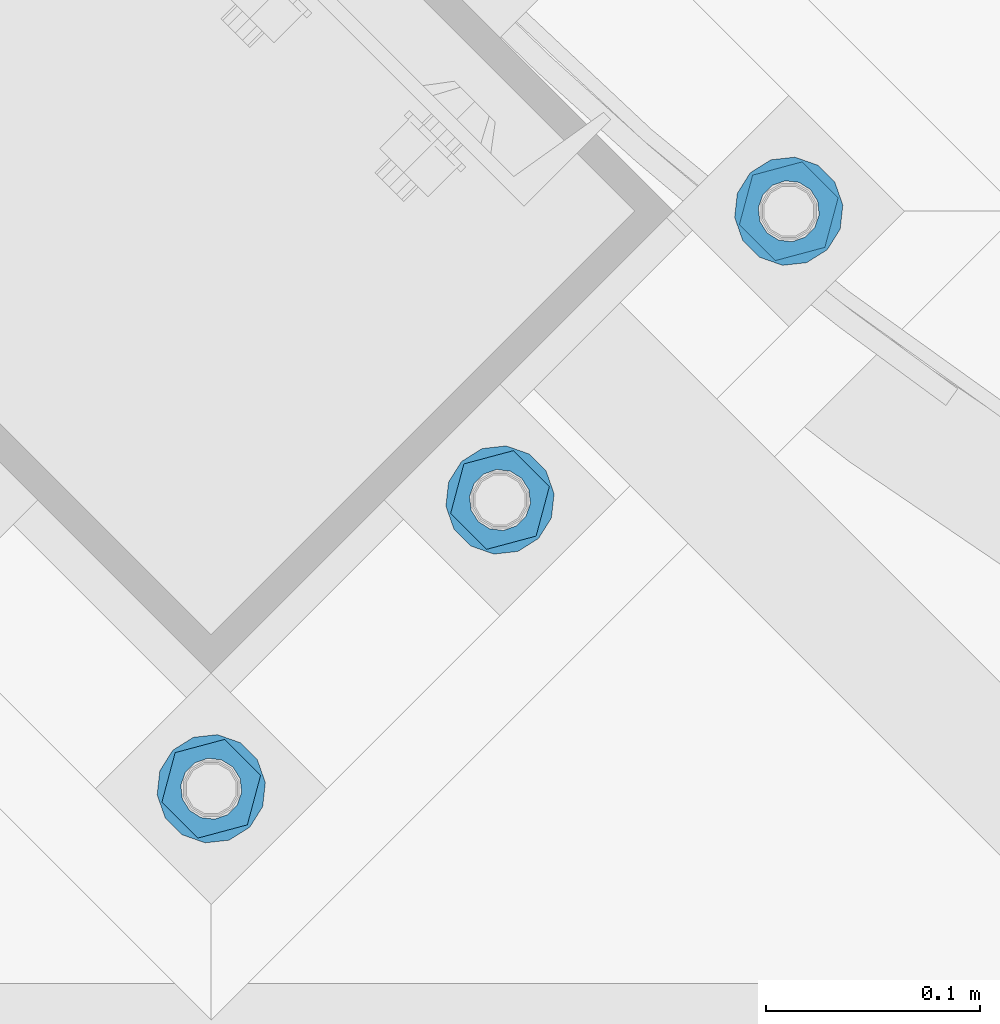
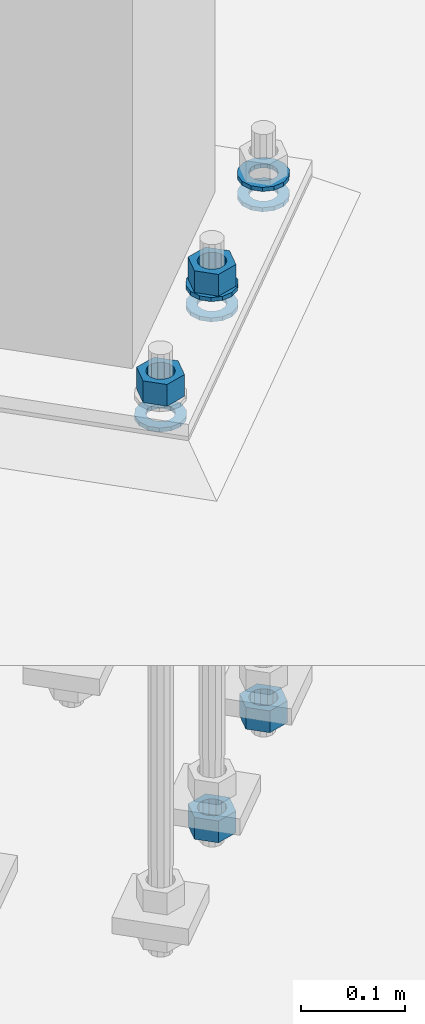
# One storey, part 862 of 1876: 9 columns, 1 element without a shape of its own.
"""IFC2X3 building model written with IfcOpenShell, lengths in millimetres."""

import ifcopenshell
import ifcopenshell.guid

model = None  # the IFC model being written
_history = None  # IfcOwnerHistory: only IFC2X3 demands one
_inside = {}  # id of a spatial element -> (the spatial element, [elements in it])
_under = {}  # id of a project, library or spatial element -> (it, [spatial elements below it])
_declared = {}  # id of a project -> (the project, [libraries it declares])
_typed = {}  # id of a type object -> (the type object, [elements of that type])
_made_of = {}  # id of a material, layer set ... -> (it, [elements and type objects made of it])


def new_model(schema):
    """Start an empty IFC model of exactly this schema.

    Asked for "IFC4X3", IfcOpenShell would pick the latest addendum, in which some entities
    have other attributes; the version numbers below select the first issue.
    IFC2X3 requires an IfcOwnerHistory on every rooted entity: one is made here for all.
    """
    global model, _history
    if schema == "IFC4X3":
        model = ifcopenshell.file(schema_version=(4, 3, 0, 0))
    else:
        model = ifcopenshell.file(schema=schema)
    _inside.clear()
    _under.clear()
    _declared.clear()
    _typed.clear()
    _made_of.clear()
    _history = None
    if model.schema == "IFC2X3":
        org = make("IfcOrganization", Name="unknown")
        user = make(
            "IfcPersonAndOrganization",
            ThePerson=make("IfcPerson", FamilyName="unknown"),
            TheOrganization=org,
        )
        app = make(
            "IfcApplication",
            ApplicationDeveloper=org,
            Version="unknown",
            ApplicationFullName="unknown",
            ApplicationIdentifier="unknown",
        )
        _history = make(
            "IfcOwnerHistory",
            OwningUser=user,
            OwningApplication=app,
            ChangeAction="ADDED",
            CreationDate=0,
        )
    return model


def make(cls, **values):
    """One entity of the class cls with the attributes given. An attribute that is None is left unset."""
    return model.create_entity(
        cls, **{name: value for name, value in values.items() if value is not None}
    )


def rooted(cls, **values):
    """An entity with a GlobalId (a new one), such as an element, a storey or a relation."""
    return make(cls, GlobalId=ifcopenshell.guid.new(), OwnerHistory=_history, **values)


def si_unit(unit_type, name, prefix=None):
    """IfcSIUnit, for example si_unit("LENGTHUNIT", "METRE", prefix="MILLI")."""
    return make("IfcSIUnit", UnitType=unit_type, Prefix=prefix, Name=name)


def assignment(units):
    """IfcUnitAssignment: the units of a project."""
    return None if units is None else make("IfcUnitAssignment", Units=units)


def point(xyz):
    """IfcCartesianPoint."""
    return None if xyz is None else make("IfcCartesianPoint", Coordinates=xyz)


def direction(xyz):
    """IfcDirection."""
    return None if xyz is None else make("IfcDirection", DirectionRatios=xyz)


def frame(location, z_axis=None, x_axis=None):
    """IfcAxis2Placement3D, a coordinate frame: its origin and axes. An axis left out is left unset."""
    return make(
        "IfcAxis2Placement3D",
        Location=point(location),
        Axis=direction(z_axis),
        RefDirection=direction(x_axis),
    )


def origin_with_axes():
    """The frame at (0, 0, 0) with the z axis (0, 0, 1) and the x axis (1, 0, 0) written out."""
    return frame((0.0, 0.0, 0.0), z_axis=(0.0, 0.0, 1.0), x_axis=(1.0, 0.0, 0.0))


def place(relative_to, where):
    """IfcLocalPlacement: puts the frame where relative to a parent placement (None: the world)."""
    return make(
        "IfcLocalPlacement", PlacementRelTo=relative_to, RelativePlacement=where
    )


def context(
    kind, dimensions, precision=None, world=None, true_north=None, identifier=None
):
    """IfcGeometricRepresentationContext, for example the 3D "Model" context."""
    return make(
        "IfcGeometricRepresentationContext",
        ContextIdentifier=identifier,
        ContextType=kind,
        CoordinateSpaceDimension=dimensions,
        Precision=precision,
        WorldCoordinateSystem=world,
        TrueNorth=true_north,
    )


def subcontext(parent, identifier, kind, view, scale=None):
    """IfcGeometricRepresentationSubContext, for example "Body" below "Model"."""
    return make(
        "IfcGeometricRepresentationSubContext",
        ContextIdentifier=identifier,
        ContextType=kind,
        ParentContext=parent,
        TargetScale=scale,
        TargetView=view,
    )


def project(units=None, contexts=None):
    """IfcProject with its units and contexts."""
    return rooted(
        "IfcProject",
        Name="project",
        RepresentationContexts=contexts,
        UnitsInContext=assignment(units),
    )


def spatial(cls, under=None, at=None, **own):
    """A site, building, storey or space (cls), placed at a placement, below another one or the project."""
    s = rooted(cls, ObjectPlacement=at, **own)
    if under is not None:
        _under.setdefault(under.id(), (under, []))[1].append(s)
    return s


def faces_of(points, faces, orient=None, outer=None):
    """IfcFace entities. A face is a list of loops; a loop is a list of indices into points, from 0.

    orient and outer hold one flag for each loop. By default every Orientation is true, the
    first loop of a face is its IfcFaceOuterBound and the others are IfcFaceBound.
    """
    made = []
    for i, loops in enumerate(faces):
        bounds = []
        for j, loop in enumerate(loops):
            is_outer = j == 0 if outer is None else outer[i][j]
            bounds.append(
                make(
                    "IfcFaceOuterBound" if is_outer else "IfcFaceBound",
                    Bound=make("IfcPolyLoop", Polygon=[points[k] for k in loop]),
                    Orientation=True if orient is None else orient[i][j],
                )
            )
        made.append(make("IfcFace", Bounds=bounds))
    return made


def faceted_brep(points, faces, orient=None, outer=None, voids=None):
    """IfcFacetedBrep: a solid bounded by flat faces; with voids (closed shells), ...WithVoids."""
    shared = [point(p) for p in points]
    hull = make("IfcClosedShell", CfsFaces=faces_of(shared, faces, orient, outer))
    if voids is None:
        return make("IfcFacetedBrep", Outer=hull)
    return make(
        "IfcFacetedBrepWithVoids",
        Outer=hull,
        Voids=[
            make(cls, CfsFaces=faces_of(shared, fs, o, b)) for cls, fs, o, b in voids
        ],
    )


def shape(context_of_items, identifier, shape_type, items):
    """IfcShapeRepresentation: the items that make up one representation, for example the "Body"."""
    return make(
        "IfcShapeRepresentation",
        ContextOfItems=context_of_items,
        RepresentationIdentifier=identifier,
        RepresentationType=shape_type,
        Items=items,
    )


def material(Name=None, Category=None):
    """IfcMaterial."""
    return make("IfcMaterial", Name=Name, Category=Category)


def made_of(thing, what):
    """Note that an element or type object is made of a material, layer set ...; save() writes the relation."""
    if what is not None:
        _made_of.setdefault(what.id(), (what, []))[1].append(thing)
    return thing


def type_object(cls, material=None, **own):
    """A type object (cls), such as IfcWallType, which elements share."""
    return made_of(rooted(cls, **own), material)


def element(
    cls,
    number,
    at=None,
    inside=None,
    cuts=None,
    type_object=None,
    material=None,
    context=None,
    identifier="Body",
    shape_type=None,
    held_by="IfcProductDefinitionShape",
    body=None,
    shapes=None,
    **own,
):
    """One element of the class cls, such as IfcWall. Its Tag is "e" and its number.

    at: its placement. inside: the storey or other place that contains it. cuts: it is an
    opening in that element (IfcRelVoidsElement). A single representation is given by context,
    identifier, shape_type and body (its items); several are given by shapes. held_by: the class
    of the entity that holds the representations. save() writes the other relations.
    """
    e = rooted(cls, Tag="e%d" % number, ObjectPlacement=at, **own)
    if body is not None:
        shapes = [shape(context, identifier, shape_type, body)]
    if shapes is not None:
        e.Representation = make(held_by, Representations=shapes)
    if inside is not None:
        _inside.setdefault(inside.id(), (inside, []))[1].append(e)
    if cuts is not None:
        rooted(
            "IfcRelVoidsElement", RelatingBuildingElement=cuts, RelatedOpeningElement=e
        )
    if type_object is not None:
        _typed.setdefault(type_object.id(), (type_object, []))[1].append(e)
    return made_of(e, material)


def aggregate(whole, parts):
    """IfcRelAggregates: a whole, such as a stair, and the parts it consists of."""
    return rooted("IfcRelAggregates", RelatingObject=whole, RelatedObjects=parts)


def save(model, path):
    """Write the relations noted so far, then the file.

    IfcRelAggregates (storeys below a building ...), IfcRelContainedInSpatialStructure (elements
    in a storey), IfcRelDefinesByType, IfcRelAssociatesMaterial and IfcRelDeclares: one each for
    every whole, place, type object, material and project.
    """
    for whole, parts in _under.values():
        aggregate(whole, parts)
    for where, things in _inside.values():
        rooted(
            "IfcRelContainedInSpatialStructure",
            RelatedElements=things,
            RelatingStructure=where,
        )
    for kind, things in _typed.values():
        rooted("IfcRelDefinesByType", RelatedObjects=things, RelatingType=kind)
    for what, things in _made_of.values():
        rooted("IfcRelAssociatesMaterial", RelatedObjects=things, RelatingMaterial=what)
    for by, libraries in _declared.values():
        rooted("IfcRelDeclares", RelatingContext=by, RelatedDefinitions=libraries)
    model.write(path)


model = new_model("IFC2X3")

# Units and contexts
model_context = context("Model", 3, precision=1e-05, world=origin_with_axes())
body_context = subcontext(model_context, "Body", "Model", "MODEL_VIEW")
ifc_project = project(units=[si_unit("LENGTHUNIT", "METRE", prefix="MILLI"), si_unit("AREAUNIT", "SQUARE_METRE"), si_unit("VOLUMEUNIT", "CUBIC_METRE"), si_unit("MASSUNIT", "GRAM", prefix="KILO"), si_unit("TIMEUNIT", "SECOND"), si_unit("PLANEANGLEUNIT", "RADIAN"), si_unit("SOLIDANGLEUNIT", "STERADIAN"), si_unit("THERMODYNAMICTEMPERATUREUNIT", "DEGREE_CELSIUS"), si_unit("LUMINOUSINTENSITYUNIT", "LUMEN")], contexts=[model_context])

# Site, building, storey
site_placement = place(None, origin_with_axes())
site = spatial("IfcSite", under=ifc_project, at=site_placement, CompositionType="ELEMENT")
building_placement = place(site_placement, origin_with_axes())
building = spatial("IfcBuilding", under=site, at=building_placement, Name="Undefined", CompositionType="ELEMENT")
storey_placement = place(building_placement, origin_with_axes())
storey = spatial("IfcBuildingStorey", under=building, at=storey_placement, Name="Undefined", CompositionType="ELEMENT", Elevation=0.0)

# Assembly, columns
assembly_placement = place(storey_placement, origin_with_axes())
assembly = element("IfcElementAssembly", 1, at=assembly_placement, inside=storey, Name="TEMPLATE", AssemblyPlace="NOTDEFINED", PredefinedType="RIGID_FRAME")
ifc_material_1 = material(Name="STEEL/A563")
column_type_1 = type_object("IfcColumnType", Name="1_HEAVY_HEX_NUT", PredefinedType="NOTDEFINED")
column_1_placement = place(assembly_placement, frame((4052.32985770467, -14987.6778259282, -552.45), z_axis=(0.707106781186548, 0.707106781186547, 0.0), x_axis=(0.0, 0.0, -1.0)))
column_1 = element("IfcColumn", 2, at=column_1_placement, type_object=column_type_1, material=ifc_material_1, Name="NUT", ObjectType="1_HEAVY_HEX_NUT", context=body_context, shape_type="Brep", body=[
    faceted_brep([(0.0, -23.8099994659442, 9.09494701772928e-13), (0.0, -11.9099998474121, -20.6200008392352), (25.4, -11.9099998474157, -20.6200008392361), (25.4, -23.8099994659478, 0.0), (0.0, 11.9099998474157, -20.620000839237), (25.4, 11.9099998474121, -20.620000839237), (0.0, 23.8099994659478, 9.09494701772928e-13), (25.4, 23.8099994659442, 0.0), (0.0, 11.9099998474157, 20.620000839237), (25.4, 11.9099998474121, 20.620000839237), (0.0, -11.9099998474121, 20.6200008392389), (25.4, -11.9099998474157, 20.6200008392379), (0.0, 1.81898940354586e-12, 14.2899999618567), (0.0, 6.20019861543915, 12.8748450879584), (25.4, 6.20019861543733, 12.8748450879593), (25.4, 0.0, 14.2899999618558), (0.0, 11.1723718546473, 8.90966924477925), (25.4, 11.1723718546436, 8.90966924477925), (0.0, 13.9317198278914, 3.17982413774916), (25.4, 13.9317198278877, 3.17982413775007), (0.0, 13.9317198278914, -3.17982413774644), (25.4, 13.9317198278895, -3.17982413774735), (0.0, 11.1723718546473, -8.90966924477834), (25.4, 11.1723718546455, -8.90966924477925), (0.0, 6.20019861544279, -12.8748450879575), (25.4, 6.20019861543915, -12.8748450879584), (0.0, 3.63797880709171e-12, -14.2899999618548), (25.4, -3.63797880709171e-12, -14.2899999618548), (0.0, -6.20019861543733, -12.8748450879566), (25.4, -6.20019861544097, -12.8748450879584), (0.0, -11.1723718546455, -8.90966924477743), (25.4, -11.1723718546473, -8.90966924477834), (0.0, -13.9317198278877, -3.17982413774735), (25.4, -13.9317198278914, -3.17982413774826), (0.0, -13.9317198278895, 3.17982413774735), (25.4, -13.9317198278914, 3.17982413774826), (0.0, -11.1723718546455, 8.90966924477925), (25.4, -11.1723718546473, 8.90966924478016), (0.0, -6.20019861543915, 12.8748450879593), (25.4, -6.20019861544279, 12.8748450879593)], [[[0, 1, 2, 3]], [[1, 4, 5, 2]], [[4, 6, 7, 5]], [[6, 8, 9, 7]], [[8, 10, 11, 9]], [[10, 0, 3, 11]], [[12, 13, 14, 15]], [[13, 16, 17, 14]], [[16, 18, 19, 17]], [[18, 20, 21, 19]], [[20, 22, 23, 21]], [[22, 24, 25, 23]], [[24, 26, 27, 25]], [[26, 28, 29, 27]], [[28, 30, 31, 29]], [[30, 32, 33, 31]], [[32, 34, 35, 33]], [[34, 36, 37, 35]], [[36, 38, 39, 37]], [[38, 12, 15, 39]], [[5, 7, 9, 11, 3, 2], [17, 19, 21, 23, 25, 27, 29, 31, 33, 35, 37, 39, 15, 14]], [[10, 8, 6, 4, 1, 0], [38, 36, 34, 32, 30, 28, 26, 24, 22, 20, 18, 16, 13, 12]]]),
])
column_2_placement = place(assembly_placement, frame((3917.62601588861, -15122.3816677443, 87.3125), z_axis=(0.707106781186548, 0.707106781186547, 0.0), x_axis=(0.0, 0.0, -1.0)))
column_2 = element("IfcColumn", 3, at=column_2_placement, type_object=column_type_1, material=ifc_material_1, Name="NUT", ObjectType="1_HEAVY_HEX_NUT", context=body_context, shape_type="Brep", body=[
    faceted_brep([(0.0, -23.8099994659442, 9.09494701772928e-13), (0.0, -11.9099998474121, -20.6200008392352), (25.4, -11.9099998474157, -20.6200008392361), (25.4, -23.8099994659478, 0.0), (0.0, 11.9099998474157, -20.620000839237), (25.4, 11.9099998474121, -20.620000839237), (0.0, 23.8099994659478, 9.09494701772928e-13), (25.4, 23.8099994659442, 0.0), (0.0, 11.9099998474157, 20.620000839237), (25.4, 11.9099998474121, 20.620000839237), (0.0, -11.9099998474121, 20.6200008392389), (25.4, -11.9099998474157, 20.6200008392379), (0.0, 1.81898940354586e-12, 14.2899999618567), (0.0, 6.20019861543915, 12.8748450879584), (25.4, 6.20019861543733, 12.8748450879593), (25.4, 0.0, 14.2899999618558), (0.0, 11.1723718546473, 8.90966924477925), (25.4, 11.1723718546436, 8.90966924477925), (0.0, 13.9317198278914, 3.17982413774916), (25.4, 13.9317198278877, 3.17982413775007), (0.0, 13.9317198278914, -3.17982413774644), (25.4, 13.9317198278895, -3.17982413774735), (0.0, 11.1723718546473, -8.90966924477834), (25.4, 11.1723718546455, -8.90966924477925), (0.0, 6.20019861544279, -12.8748450879575), (25.4, 6.20019861543915, -12.8748450879584), (0.0, 3.63797880709171e-12, -14.2899999618548), (25.4, -3.63797880709171e-12, -14.2899999618548), (0.0, -6.20019861543733, -12.8748450879566), (25.4, -6.20019861544097, -12.8748450879584), (0.0, -11.1723718546455, -8.90966924477743), (25.4, -11.1723718546473, -8.90966924477834), (0.0, -13.9317198278877, -3.17982413774735), (25.4, -13.9317198278914, -3.17982413774826), (0.0, -13.9317198278895, 3.17982413774735), (25.4, -13.9317198278914, 3.17982413774826), (0.0, -11.1723718546455, 8.90966924477925), (25.4, -11.1723718546473, 8.90966924478016), (0.0, -6.20019861543915, 12.8748450879593), (25.4, -6.20019861544279, 12.8748450879593)], [[[0, 1, 2, 3]], [[1, 4, 5, 2]], [[4, 6, 7, 5]], [[6, 8, 9, 7]], [[8, 10, 11, 9]], [[10, 0, 3, 11]], [[12, 13, 14, 15]], [[13, 16, 17, 14]], [[16, 18, 19, 17]], [[18, 20, 21, 19]], [[20, 22, 23, 21]], [[22, 24, 25, 23]], [[24, 26, 27, 25]], [[26, 28, 29, 27]], [[28, 30, 31, 29]], [[30, 32, 33, 31]], [[32, 34, 35, 33]], [[34, 36, 37, 35]], [[36, 38, 39, 37]], [[38, 12, 15, 39]], [[5, 7, 9, 11, 3, 2], [17, 19, 21, 23, 25, 27, 29, 31, 33, 35, 37, 39, 15, 14]], [[10, 8, 6, 4, 1, 0], [38, 36, 34, 32, 30, 28, 26, 24, 22, 20, 18, 16, 13, 12]]]),
])
column_3_placement = place(assembly_placement, frame((3917.62601588852, -15122.3816677443, -552.45), z_axis=(0.707106781186548, 0.707106781186547, 0.0), x_axis=(0.0, 0.0, -1.0)))
column_3 = element("IfcColumn", 4, at=column_3_placement, type_object=column_type_1, material=ifc_material_1, Name="NUT", ObjectType="1_HEAVY_HEX_NUT", context=body_context, shape_type="Brep", body=[
    faceted_brep([(0.0, -23.8099994659442, 9.09494701772928e-13), (0.0, -11.9099998474121, -20.6200008392352), (25.4, -11.9099998474157, -20.6200008392361), (25.4, -23.8099994659478, 0.0), (0.0, 11.9099998474157, -20.620000839237), (25.4, 11.9099998474121, -20.620000839237), (0.0, 23.8099994659478, 9.09494701772928e-13), (25.4, 23.8099994659442, 0.0), (0.0, 11.9099998474157, 20.620000839237), (25.4, 11.9099998474121, 20.620000839237), (0.0, -11.9099998474121, 20.6200008392389), (25.4, -11.9099998474157, 20.6200008392379), (0.0, 1.81898940354586e-12, 14.2899999618567), (0.0, 6.20019861543915, 12.8748450879584), (25.4, 6.20019861543733, 12.8748450879593), (25.4, 0.0, 14.2899999618558), (0.0, 11.1723718546473, 8.90966924477925), (25.4, 11.1723718546436, 8.90966924477925), (0.0, 13.9317198278914, 3.17982413774916), (25.4, 13.9317198278877, 3.17982413775007), (0.0, 13.9317198278914, -3.17982413774644), (25.4, 13.9317198278895, -3.17982413774735), (0.0, 11.1723718546473, -8.90966924477834), (25.4, 11.1723718546455, -8.90966924477925), (0.0, 6.20019861544279, -12.8748450879575), (25.4, 6.20019861543915, -12.8748450879584), (0.0, 3.63797880709171e-12, -14.2899999618548), (25.4, -3.63797880709171e-12, -14.2899999618548), (0.0, -6.20019861543733, -12.8748450879566), (25.4, -6.20019861544097, -12.8748450879584), (0.0, -11.1723718546455, -8.90966924477743), (25.4, -11.1723718546473, -8.90966924477834), (0.0, -13.9317198278877, -3.17982413774735), (25.4, -13.9317198278914, -3.17982413774826), (0.0, -13.9317198278895, 3.17982413774735), (25.4, -13.9317198278914, 3.17982413774826), (0.0, -11.1723718546455, 8.90966924477925), (25.4, -11.1723718546473, 8.90966924478016), (0.0, -6.20019861543915, 12.8748450879593), (25.4, -6.20019861544279, 12.8748450879593)], [[[0, 1, 2, 3]], [[1, 4, 5, 2]], [[4, 6, 7, 5]], [[6, 8, 9, 7]], [[8, 10, 11, 9]], [[10, 0, 3, 11]], [[12, 13, 14, 15]], [[13, 16, 17, 14]], [[16, 18, 19, 17]], [[18, 20, 21, 19]], [[20, 22, 23, 21]], [[22, 24, 25, 23]], [[24, 26, 27, 25]], [[26, 28, 29, 27]], [[28, 30, 31, 29]], [[30, 32, 33, 31]], [[32, 34, 35, 33]], [[34, 36, 37, 35]], [[36, 38, 39, 37]], [[38, 12, 15, 39]], [[5, 7, 9, 11, 3, 2], [17, 19, 21, 23, 25, 27, 29, 31, 33, 35, 37, 39, 15, 14]], [[10, 8, 6, 4, 1, 0], [38, 36, 34, 32, 30, 28, 26, 24, 22, 20, 18, 16, 13, 12]]]),
])
column_4_placement = place(assembly_placement, frame((3782.92217407241, -15257.0855095605, 87.3125), z_axis=(0.707106781186548, 0.707106781186547, 0.0), x_axis=(0.0, 0.0, -1.0)))
column_4 = element("IfcColumn", 5, at=column_4_placement, type_object=column_type_1, material=ifc_material_1, Name="NUT", ObjectType="1_HEAVY_HEX_NUT", context=body_context, shape_type="Brep", body=[
    faceted_brep([(0.0, -23.8099994659442, 9.09494701772928e-13), (0.0, -11.9099998474121, -20.6200008392352), (25.4, -11.9099998474157, -20.6200008392361), (25.4, -23.8099994659478, 0.0), (0.0, 11.9099998474157, -20.620000839237), (25.4, 11.9099998474121, -20.620000839237), (0.0, 23.8099994659478, 9.09494701772928e-13), (25.4, 23.8099994659442, 0.0), (0.0, 11.9099998474157, 20.620000839237), (25.4, 11.9099998474121, 20.620000839237), (0.0, -11.9099998474121, 20.6200008392389), (25.4, -11.9099998474157, 20.6200008392379), (0.0, 1.81898940354586e-12, 14.2899999618567), (0.0, 6.20019861543915, 12.8748450879584), (25.4, 6.20019861543733, 12.8748450879593), (25.4, 0.0, 14.2899999618558), (0.0, 11.1723718546473, 8.90966924477925), (25.4, 11.1723718546436, 8.90966924477925), (0.0, 13.9317198278914, 3.17982413774916), (25.4, 13.9317198278877, 3.17982413775007), (0.0, 13.9317198278914, -3.17982413774644), (25.4, 13.9317198278895, -3.17982413774735), (0.0, 11.1723718546473, -8.90966924477834), (25.4, 11.1723718546455, -8.90966924477925), (0.0, 6.20019861544279, -12.8748450879575), (25.4, 6.20019861543915, -12.8748450879584), (0.0, 3.63797880709171e-12, -14.2899999618548), (25.4, -3.63797880709171e-12, -14.2899999618548), (0.0, -6.20019861543733, -12.8748450879566), (25.4, -6.20019861544097, -12.8748450879584), (0.0, -11.1723718546455, -8.90966924477743), (25.4, -11.1723718546473, -8.90966924477834), (0.0, -13.9317198278877, -3.17982413774735), (25.4, -13.9317198278914, -3.17982413774826), (0.0, -13.9317198278895, 3.17982413774735), (25.4, -13.9317198278914, 3.17982413774826), (0.0, -11.1723718546455, 8.90966924477925), (25.4, -11.1723718546473, 8.90966924478016), (0.0, -6.20019861543915, 12.8748450879593), (25.4, -6.20019861544279, 12.8748450879593)], [[[0, 1, 2, 3]], [[1, 4, 5, 2]], [[4, 6, 7, 5]], [[6, 8, 9, 7]], [[8, 10, 11, 9]], [[10, 0, 3, 11]], [[12, 13, 14, 15]], [[13, 16, 17, 14]], [[16, 18, 19, 17]], [[18, 20, 21, 19]], [[20, 22, 23, 21]], [[22, 24, 25, 23]], [[24, 26, 27, 25]], [[26, 28, 29, 27]], [[28, 30, 31, 29]], [[30, 32, 33, 31]], [[32, 34, 35, 33]], [[34, 36, 37, 35]], [[36, 38, 39, 37]], [[38, 12, 15, 39]], [[5, 7, 9, 11, 3, 2], [17, 19, 21, 23, 25, 27, 29, 31, 33, 35, 37, 39, 15, 14]], [[10, 8, 6, 4, 1, 0], [38, 36, 34, 32, 30, 28, 26, 24, 22, 20, 18, 16, 13, 12]]]),
])
ifc_material_2 = material(Name="STEEL/F436")
column_type_2 = type_object("IfcColumnType", Name="1_WASHER", PredefinedType="NOTDEFINED")
column_5_placement = place(assembly_placement, frame((4052.32985770481, -14987.677825928, 38.1), z_axis=(0.707106781186548, 0.707106781186547, 0.0), x_axis=(0.0, 0.0, -1.0)))
column_5 = element("IfcColumn", 6, at=column_5_placement, type_object=column_type_2, material=ifc_material_2, Name="WASHER", ObjectType="1_WASHER", context=body_context, shape_type="Brep", body=[
    faceted_brep([(0.0, -25.3999996185375, 0.0), (0.0, -22.8846089010331, -11.0206468080742), (4.7625, -22.8846089010331, -11.0206468080742), (4.7625, -25.3999996185375, 0.0), (0.0, -15.8366407293743, -19.8585193564477), (4.7625, -15.8366407293743, -19.8585193564477), (0.0, -5.65203163760816, -24.7631685975166), (4.7625, -5.65203163760816, -24.7631685975166), (0.0, 5.65203163760452, -24.7631685975166), (4.7625, 5.65203163760452, -24.7631685975166), (0.0, 15.8366407293706, -19.858519356445), (4.7625, 15.8366407293706, -19.858519356445), (0.0, 22.8846089010331, -11.0206468080733), (4.7625, 22.8846089010331, -11.0206468080733), (0.0, 25.3999996185339, 9.09494701772928e-13), (4.7625, 25.3999996185339, 9.09494701772928e-13), (0.0, 22.8846089010331, 11.0206468080751), (4.7625, 22.8846089010331, 11.0206468080751), (0.0, 15.8366407293706, 19.8585193564486), (4.7625, 15.8366407293706, 19.8585193564486), (0.0, 5.65203163760452, 24.7631685975175), (4.7625, 5.65203163760452, 24.7631685975175), (0.0, -5.65203163760816, 24.7631685975175), (4.7625, -5.65203163760816, 24.7631685975175), (0.0, -15.8366407293724, 19.8585193564459), (4.7625, -15.8366407293724, 19.8585193564459), (0.0, -22.8846089010367, 11.0206468080751), (4.7625, -22.8846089010367, 11.0206468080751), (0.0, 1.81898940354586e-12, 14.2899999618567), (0.0, 6.20019861543915, 12.8748450879584), (4.7625, 6.20019861543733, 12.8748450879593), (4.7625, 0.0, 14.2899999618558), (0.0, 11.1723718546473, 8.90966924477925), (4.7625, 11.1723718546436, 8.90966924477925), (0.0, 13.9317198278914, 3.17982413774916), (4.7625, 13.9317198278877, 3.17982413775007), (0.0, 13.9317198278914, -3.17982413774644), (4.7625, 13.9317198278895, -3.17982413774735), (0.0, 11.1723718546473, -8.90966924477834), (4.7625, 11.1723718546455, -8.90966924477925), (0.0, 6.20019861544279, -12.8748450879575), (4.7625, 6.20019861543915, -12.8748450879584), (0.0, 3.63797880709171e-12, -14.2899999618548), (4.7625, -3.63797880709171e-12, -14.2899999618548), (0.0, -6.20019861543733, -12.8748450879566), (4.7625, -6.20019861544097, -12.8748450879584), (0.0, -11.1723718546455, -8.90966924477743), (4.7625, -11.1723718546473, -8.90966924477834), (0.0, -13.9317198278877, -3.17982413774735), (4.7625, -13.9317198278914, -3.17982413774826), (0.0, -13.9317198278895, 3.17982413774735), (4.7625, -13.9317198278914, 3.17982413774826), (0.0, -11.1723718546455, 8.90966924477925), (4.7625, -11.1723718546473, 8.90966924478016), (0.0, -6.20019861543915, 12.8748450879593), (4.7625, -6.20019861544279, 12.8748450879593)], [[[0, 1, 2, 3]], [[1, 4, 5, 2]], [[4, 6, 7, 5]], [[6, 8, 9, 7]], [[8, 10, 11, 9]], [[10, 12, 13, 11]], [[12, 14, 15, 13]], [[14, 16, 17, 15]], [[16, 18, 19, 17]], [[18, 20, 21, 19]], [[20, 22, 23, 21]], [[22, 24, 25, 23]], [[24, 26, 27, 25]], [[26, 0, 3, 27]], [[28, 29, 30, 31]], [[29, 32, 33, 30]], [[32, 34, 35, 33]], [[34, 36, 37, 35]], [[36, 38, 39, 37]], [[38, 40, 41, 39]], [[40, 42, 43, 41]], [[42, 44, 45, 43]], [[44, 46, 47, 45]], [[46, 48, 49, 47]], [[48, 50, 51, 49]], [[50, 52, 53, 51]], [[52, 54, 55, 53]], [[54, 28, 31, 55]], [[5, 7, 9, 11, 13, 15, 17, 19, 21, 23, 25, 27, 3, 2], [33, 35, 37, 39, 41, 43, 45, 47, 49, 51, 53, 55, 31, 30]], [[26, 24, 22, 20, 18, 16, 14, 12, 10, 8, 6, 4, 1, 0], [54, 52, 50, 48, 46, 44, 42, 40, 38, 36, 34, 32, 29, 28]]]),
])
column_6_placement = place(assembly_placement, frame((4052.32985770494, -14987.677825928, 61.9125), z_axis=(0.707106781186548, 0.707106781186547, 0.0), x_axis=(0.0, 0.0, -1.0)))
column_6 = element("IfcColumn", 7, at=column_6_placement, type_object=column_type_2, material=ifc_material_2, Name="WASHER", ObjectType="1_WASHER", context=body_context, shape_type="Brep", body=[
    faceted_brep([(0.0, -25.3999996185375, 0.0), (0.0, -22.8846089010331, -11.0206468080742), (4.7625, -22.8846089010331, -11.0206468080742), (4.7625, -25.3999996185375, 0.0), (0.0, -15.8366407293743, -19.8585193564477), (4.7625, -15.8366407293743, -19.8585193564477), (0.0, -5.65203163760816, -24.7631685975166), (4.7625, -5.65203163760816, -24.7631685975166), (0.0, 5.65203163760452, -24.7631685975166), (4.7625, 5.65203163760452, -24.7631685975166), (0.0, 15.8366407293706, -19.858519356445), (4.7625, 15.8366407293706, -19.858519356445), (0.0, 22.8846089010331, -11.0206468080733), (4.7625, 22.8846089010331, -11.0206468080733), (0.0, 25.3999996185339, 9.09494701772928e-13), (4.7625, 25.3999996185339, 9.09494701772928e-13), (0.0, 22.8846089010331, 11.0206468080751), (4.7625, 22.8846089010331, 11.0206468080751), (0.0, 15.8366407293706, 19.8585193564486), (4.7625, 15.8366407293706, 19.8585193564486), (0.0, 5.65203163760452, 24.7631685975175), (4.7625, 5.65203163760452, 24.7631685975175), (0.0, -5.65203163760816, 24.7631685975175), (4.7625, -5.65203163760816, 24.7631685975175), (0.0, -15.8366407293724, 19.8585193564459), (4.7625, -15.8366407293724, 19.8585193564459), (0.0, -22.8846089010367, 11.0206468080751), (4.7625, -22.8846089010367, 11.0206468080751), (0.0, 1.81898940354586e-12, 14.2899999618567), (0.0, 6.20019861543915, 12.8748450879584), (4.7625, 6.20019861543733, 12.8748450879593), (4.7625, 0.0, 14.2899999618558), (0.0, 11.1723718546473, 8.90966924477925), (4.7625, 11.1723718546436, 8.90966924477925), (0.0, 13.9317198278914, 3.17982413774916), (4.7625, 13.9317198278877, 3.17982413775007), (0.0, 13.9317198278914, -3.17982413774644), (4.7625, 13.9317198278895, -3.17982413774735), (0.0, 11.1723718546473, -8.90966924477834), (4.7625, 11.1723718546455, -8.90966924477925), (0.0, 6.20019861544279, -12.8748450879575), (4.7625, 6.20019861543915, -12.8748450879584), (0.0, 3.63797880709171e-12, -14.2899999618548), (4.7625, -3.63797880709171e-12, -14.2899999618548), (0.0, -6.20019861543733, -12.8748450879566), (4.7625, -6.20019861544097, -12.8748450879584), (0.0, -11.1723718546455, -8.90966924477743), (4.7625, -11.1723718546473, -8.90966924477834), (0.0, -13.9317198278877, -3.17982413774735), (4.7625, -13.9317198278914, -3.17982413774826), (0.0, -13.9317198278895, 3.17982413774735), (4.7625, -13.9317198278914, 3.17982413774826), (0.0, -11.1723718546455, 8.90966924477925), (4.7625, -11.1723718546473, 8.90966924478016), (0.0, -6.20019861543915, 12.8748450879593), (4.7625, -6.20019861544279, 12.8748450879593)], [[[0, 1, 2, 3]], [[1, 4, 5, 2]], [[4, 6, 7, 5]], [[6, 8, 9, 7]], [[8, 10, 11, 9]], [[10, 12, 13, 11]], [[12, 14, 15, 13]], [[14, 16, 17, 15]], [[16, 18, 19, 17]], [[18, 20, 21, 19]], [[20, 22, 23, 21]], [[22, 24, 25, 23]], [[24, 26, 27, 25]], [[26, 0, 3, 27]], [[28, 29, 30, 31]], [[29, 32, 33, 30]], [[32, 34, 35, 33]], [[34, 36, 37, 35]], [[36, 38, 39, 37]], [[38, 40, 41, 39]], [[40, 42, 43, 41]], [[42, 44, 45, 43]], [[44, 46, 47, 45]], [[46, 48, 49, 47]], [[48, 50, 51, 49]], [[50, 52, 53, 51]], [[52, 54, 55, 53]], [[54, 28, 31, 55]], [[5, 7, 9, 11, 13, 15, 17, 19, 21, 23, 25, 27, 3, 2], [33, 35, 37, 39, 41, 43, 45, 47, 49, 51, 53, 55, 31, 30]], [[26, 24, 22, 20, 18, 16, 14, 12, 10, 8, 6, 4, 1, 0], [54, 52, 50, 48, 46, 44, 42, 40, 38, 36, 34, 32, 29, 28]]]),
])
column_7_placement = place(assembly_placement, frame((3917.62601588861, -15122.3816677442, 38.1), z_axis=(0.707106781186548, 0.707106781186547, 0.0), x_axis=(0.0, 0.0, -1.0)))
column_7 = element("IfcColumn", 8, at=column_7_placement, type_object=column_type_2, material=ifc_material_2, Name="WASHER", ObjectType="1_WASHER", context=body_context, shape_type="Brep", body=[
    faceted_brep([(0.0, -25.3999996185375, 0.0), (0.0, -22.8846089010331, -11.0206468080742), (4.7625, -22.8846089010331, -11.0206468080742), (4.7625, -25.3999996185375, 0.0), (0.0, -15.8366407293743, -19.8585193564477), (4.7625, -15.8366407293743, -19.8585193564477), (0.0, -5.65203163760816, -24.7631685975166), (4.7625, -5.65203163760816, -24.7631685975166), (0.0, 5.65203163760452, -24.7631685975166), (4.7625, 5.65203163760452, -24.7631685975166), (0.0, 15.8366407293706, -19.858519356445), (4.7625, 15.8366407293706, -19.858519356445), (0.0, 22.8846089010331, -11.0206468080733), (4.7625, 22.8846089010331, -11.0206468080733), (0.0, 25.3999996185339, 9.09494701772928e-13), (4.7625, 25.3999996185339, 9.09494701772928e-13), (0.0, 22.8846089010331, 11.0206468080751), (4.7625, 22.8846089010331, 11.0206468080751), (0.0, 15.8366407293706, 19.8585193564486), (4.7625, 15.8366407293706, 19.8585193564486), (0.0, 5.65203163760452, 24.7631685975175), (4.7625, 5.65203163760452, 24.7631685975175), (0.0, -5.65203163760816, 24.7631685975175), (4.7625, -5.65203163760816, 24.7631685975175), (0.0, -15.8366407293724, 19.8585193564459), (4.7625, -15.8366407293724, 19.8585193564459), (0.0, -22.8846089010367, 11.0206468080751), (4.7625, -22.8846089010367, 11.0206468080751), (0.0, 1.81898940354586e-12, 14.2899999618567), (0.0, 6.20019861543915, 12.8748450879584), (4.7625, 6.20019861543733, 12.8748450879593), (4.7625, 0.0, 14.2899999618558), (0.0, 11.1723718546473, 8.90966924477925), (4.7625, 11.1723718546436, 8.90966924477925), (0.0, 13.9317198278914, 3.17982413774916), (4.7625, 13.9317198278877, 3.17982413775007), (0.0, 13.9317198278914, -3.17982413774644), (4.7625, 13.9317198278895, -3.17982413774735), (0.0, 11.1723718546473, -8.90966924477834), (4.7625, 11.1723718546455, -8.90966924477925), (0.0, 6.20019861544279, -12.8748450879575), (4.7625, 6.20019861543915, -12.8748450879584), (0.0, 3.63797880709171e-12, -14.2899999618548), (4.7625, -3.63797880709171e-12, -14.2899999618548), (0.0, -6.20019861543733, -12.8748450879566), (4.7625, -6.20019861544097, -12.8748450879584), (0.0, -11.1723718546455, -8.90966924477743), (4.7625, -11.1723718546473, -8.90966924477834), (0.0, -13.9317198278877, -3.17982413774735), (4.7625, -13.9317198278914, -3.17982413774826), (0.0, -13.9317198278895, 3.17982413774735), (4.7625, -13.9317198278914, 3.17982413774826), (0.0, -11.1723718546455, 8.90966924477925), (4.7625, -11.1723718546473, 8.90966924478016), (0.0, -6.20019861543915, 12.8748450879593), (4.7625, -6.20019861544279, 12.8748450879593)], [[[0, 1, 2, 3]], [[1, 4, 5, 2]], [[4, 6, 7, 5]], [[6, 8, 9, 7]], [[8, 10, 11, 9]], [[10, 12, 13, 11]], [[12, 14, 15, 13]], [[14, 16, 17, 15]], [[16, 18, 19, 17]], [[18, 20, 21, 19]], [[20, 22, 23, 21]], [[22, 24, 25, 23]], [[24, 26, 27, 25]], [[26, 0, 3, 27]], [[28, 29, 30, 31]], [[29, 32, 33, 30]], [[32, 34, 35, 33]], [[34, 36, 37, 35]], [[36, 38, 39, 37]], [[38, 40, 41, 39]], [[40, 42, 43, 41]], [[42, 44, 45, 43]], [[44, 46, 47, 45]], [[46, 48, 49, 47]], [[48, 50, 51, 49]], [[50, 52, 53, 51]], [[52, 54, 55, 53]], [[54, 28, 31, 55]], [[5, 7, 9, 11, 13, 15, 17, 19, 21, 23, 25, 27, 3, 2], [33, 35, 37, 39, 41, 43, 45, 47, 49, 51, 53, 55, 31, 30]], [[26, 24, 22, 20, 18, 16, 14, 12, 10, 8, 6, 4, 1, 0], [54, 52, 50, 48, 46, 44, 42, 40, 38, 36, 34, 32, 29, 28]]]),
])
column_8_placement = place(assembly_placement, frame((3917.6260158887, -15122.3816677442, 61.9125), z_axis=(0.707106781186548, 0.707106781186547, 0.0), x_axis=(0.0, 0.0, -1.0)))
column_8 = element("IfcColumn", 9, at=column_8_placement, type_object=column_type_2, material=ifc_material_2, Name="WASHER", ObjectType="1_WASHER", context=body_context, shape_type="Brep", body=[
    faceted_brep([(0.0, -25.3999996185375, 0.0), (0.0, -22.8846089010331, -11.0206468080742), (4.7625, -22.8846089010331, -11.0206468080742), (4.7625, -25.3999996185375, 0.0), (0.0, -15.8366407293743, -19.8585193564477), (4.7625, -15.8366407293743, -19.8585193564477), (0.0, -5.65203163760816, -24.7631685975166), (4.7625, -5.65203163760816, -24.7631685975166), (0.0, 5.65203163760452, -24.7631685975166), (4.7625, 5.65203163760452, -24.7631685975166), (0.0, 15.8366407293706, -19.858519356445), (4.7625, 15.8366407293706, -19.858519356445), (0.0, 22.8846089010331, -11.0206468080733), (4.7625, 22.8846089010331, -11.0206468080733), (0.0, 25.3999996185339, 9.09494701772928e-13), (4.7625, 25.3999996185339, 9.09494701772928e-13), (0.0, 22.8846089010331, 11.0206468080751), (4.7625, 22.8846089010331, 11.0206468080751), (0.0, 15.8366407293706, 19.8585193564486), (4.7625, 15.8366407293706, 19.8585193564486), (0.0, 5.65203163760452, 24.7631685975175), (4.7625, 5.65203163760452, 24.7631685975175), (0.0, -5.65203163760816, 24.7631685975175), (4.7625, -5.65203163760816, 24.7631685975175), (0.0, -15.8366407293724, 19.8585193564459), (4.7625, -15.8366407293724, 19.8585193564459), (0.0, -22.8846089010367, 11.0206468080751), (4.7625, -22.8846089010367, 11.0206468080751), (0.0, 1.81898940354586e-12, 14.2899999618567), (0.0, 6.20019861543915, 12.8748450879584), (4.7625, 6.20019861543733, 12.8748450879593), (4.7625, 0.0, 14.2899999618558), (0.0, 11.1723718546473, 8.90966924477925), (4.7625, 11.1723718546436, 8.90966924477925), (0.0, 13.9317198278914, 3.17982413774916), (4.7625, 13.9317198278877, 3.17982413775007), (0.0, 13.9317198278914, -3.17982413774644), (4.7625, 13.9317198278895, -3.17982413774735), (0.0, 11.1723718546473, -8.90966924477834), (4.7625, 11.1723718546455, -8.90966924477925), (0.0, 6.20019861544279, -12.8748450879575), (4.7625, 6.20019861543915, -12.8748450879584), (0.0, 3.63797880709171e-12, -14.2899999618548), (4.7625, -3.63797880709171e-12, -14.2899999618548), (0.0, -6.20019861543733, -12.8748450879566), (4.7625, -6.20019861544097, -12.8748450879584), (0.0, -11.1723718546455, -8.90966924477743), (4.7625, -11.1723718546473, -8.90966924477834), (0.0, -13.9317198278877, -3.17982413774735), (4.7625, -13.9317198278914, -3.17982413774826), (0.0, -13.9317198278895, 3.17982413774735), (4.7625, -13.9317198278914, 3.17982413774826), (0.0, -11.1723718546455, 8.90966924477925), (4.7625, -11.1723718546473, 8.90966924478016), (0.0, -6.20019861543915, 12.8748450879593), (4.7625, -6.20019861544279, 12.8748450879593)], [[[0, 1, 2, 3]], [[1, 4, 5, 2]], [[4, 6, 7, 5]], [[6, 8, 9, 7]], [[8, 10, 11, 9]], [[10, 12, 13, 11]], [[12, 14, 15, 13]], [[14, 16, 17, 15]], [[16, 18, 19, 17]], [[18, 20, 21, 19]], [[20, 22, 23, 21]], [[22, 24, 25, 23]], [[24, 26, 27, 25]], [[26, 0, 3, 27]], [[28, 29, 30, 31]], [[29, 32, 33, 30]], [[32, 34, 35, 33]], [[34, 36, 37, 35]], [[36, 38, 39, 37]], [[38, 40, 41, 39]], [[40, 42, 43, 41]], [[42, 44, 45, 43]], [[44, 46, 47, 45]], [[46, 48, 49, 47]], [[48, 50, 51, 49]], [[50, 52, 53, 51]], [[52, 54, 55, 53]], [[54, 28, 31, 55]], [[5, 7, 9, 11, 13, 15, 17, 19, 21, 23, 25, 27, 3, 2], [33, 35, 37, 39, 41, 43, 45, 47, 49, 51, 53, 55, 31, 30]], [[26, 24, 22, 20, 18, 16, 14, 12, 10, 8, 6, 4, 1, 0], [54, 52, 50, 48, 46, 44, 42, 40, 38, 36, 34, 32, 29, 28]]]),
])
column_9_placement = place(assembly_placement, frame((3782.92217407251, -15257.0855095605, 38.1), z_axis=(0.707106781186548, 0.707106781186547, 0.0), x_axis=(0.0, 0.0, -1.0)))
column_9 = element("IfcColumn", 10, at=column_9_placement, type_object=column_type_2, material=ifc_material_2, Name="WASHER", ObjectType="1_WASHER", context=body_context, shape_type="Brep", body=[
    faceted_brep([(0.0, -25.3999996185375, 0.0), (0.0, -22.8846089010331, -11.0206468080742), (4.7625, -22.8846089010331, -11.0206468080742), (4.7625, -25.3999996185375, 0.0), (0.0, -15.8366407293743, -19.8585193564477), (4.7625, -15.8366407293743, -19.8585193564477), (0.0, -5.65203163760816, -24.7631685975166), (4.7625, -5.65203163760816, -24.7631685975166), (0.0, 5.65203163760452, -24.7631685975166), (4.7625, 5.65203163760452, -24.7631685975166), (0.0, 15.8366407293706, -19.858519356445), (4.7625, 15.8366407293706, -19.858519356445), (0.0, 22.8846089010331, -11.0206468080733), (4.7625, 22.8846089010331, -11.0206468080733), (0.0, 25.3999996185339, 9.09494701772928e-13), (4.7625, 25.3999996185339, 9.09494701772928e-13), (0.0, 22.8846089010331, 11.0206468080751), (4.7625, 22.8846089010331, 11.0206468080751), (0.0, 15.8366407293706, 19.8585193564486), (4.7625, 15.8366407293706, 19.8585193564486), (0.0, 5.65203163760452, 24.7631685975175), (4.7625, 5.65203163760452, 24.7631685975175), (0.0, -5.65203163760816, 24.7631685975175), (4.7625, -5.65203163760816, 24.7631685975175), (0.0, -15.8366407293724, 19.8585193564459), (4.7625, -15.8366407293724, 19.8585193564459), (0.0, -22.8846089010367, 11.0206468080751), (4.7625, -22.8846089010367, 11.0206468080751), (0.0, 1.81898940354586e-12, 14.2899999618567), (0.0, 6.20019861543915, 12.8748450879584), (4.7625, 6.20019861543733, 12.8748450879593), (4.7625, 0.0, 14.2899999618558), (0.0, 11.1723718546473, 8.90966924477925), (4.7625, 11.1723718546436, 8.90966924477925), (0.0, 13.9317198278914, 3.17982413774916), (4.7625, 13.9317198278877, 3.17982413775007), (0.0, 13.9317198278914, -3.17982413774644), (4.7625, 13.9317198278895, -3.17982413774735), (0.0, 11.1723718546473, -8.90966924477834), (4.7625, 11.1723718546455, -8.90966924477925), (0.0, 6.20019861544279, -12.8748450879575), (4.7625, 6.20019861543915, -12.8748450879584), (0.0, 3.63797880709171e-12, -14.2899999618548), (4.7625, -3.63797880709171e-12, -14.2899999618548), (0.0, -6.20019861543733, -12.8748450879566), (4.7625, -6.20019861544097, -12.8748450879584), (0.0, -11.1723718546455, -8.90966924477743), (4.7625, -11.1723718546473, -8.90966924477834), (0.0, -13.9317198278877, -3.17982413774735), (4.7625, -13.9317198278914, -3.17982413774826), (0.0, -13.9317198278895, 3.17982413774735), (4.7625, -13.9317198278914, 3.17982413774826), (0.0, -11.1723718546455, 8.90966924477925), (4.7625, -11.1723718546473, 8.90966924478016), (0.0, -6.20019861543915, 12.8748450879593), (4.7625, -6.20019861544279, 12.8748450879593)], [[[0, 1, 2, 3]], [[1, 4, 5, 2]], [[4, 6, 7, 5]], [[6, 8, 9, 7]], [[8, 10, 11, 9]], [[10, 12, 13, 11]], [[12, 14, 15, 13]], [[14, 16, 17, 15]], [[16, 18, 19, 17]], [[18, 20, 21, 19]], [[20, 22, 23, 21]], [[22, 24, 25, 23]], [[24, 26, 27, 25]], [[26, 0, 3, 27]], [[28, 29, 30, 31]], [[29, 32, 33, 30]], [[32, 34, 35, 33]], [[34, 36, 37, 35]], [[36, 38, 39, 37]], [[38, 40, 41, 39]], [[40, 42, 43, 41]], [[42, 44, 45, 43]], [[44, 46, 47, 45]], [[46, 48, 49, 47]], [[48, 50, 51, 49]], [[50, 52, 53, 51]], [[52, 54, 55, 53]], [[54, 28, 31, 55]], [[5, 7, 9, 11, 13, 15, 17, 19, 21, 23, 25, 27, 3, 2], [33, 35, 37, 39, 41, 43, 45, 47, 49, 51, 53, 55, 31, 30]], [[26, 24, 22, 20, 18, 16, 14, 12, 10, 8, 6, 4, 1, 0], [54, 52, 50, 48, 46, 44, 42, 40, 38, 36, 34, 32, 29, 28]]]),
])
aggregate(assembly, [column_5, column_6, column_1, column_2, column_7, column_8, column_3, column_4, column_9])

save(model, "model.ifc")
